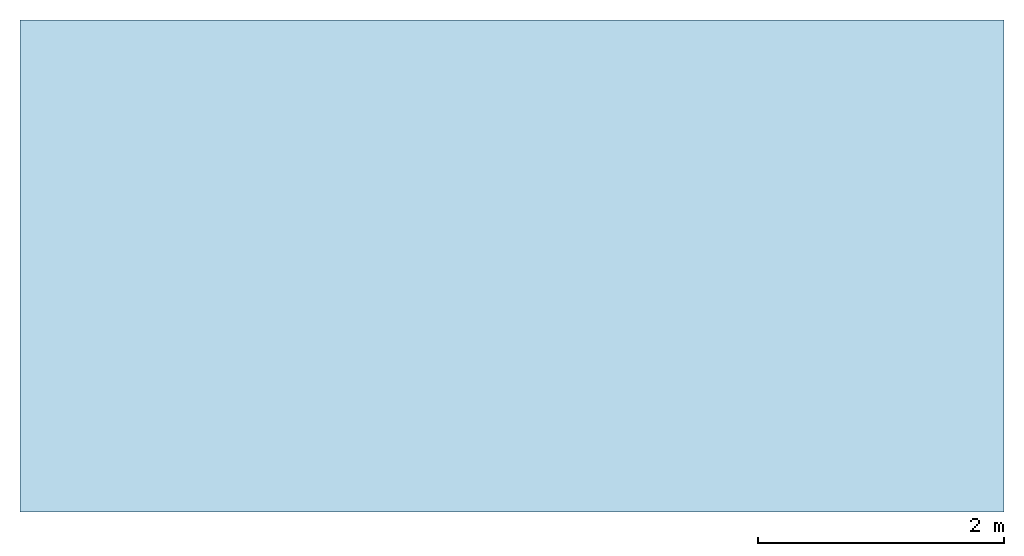
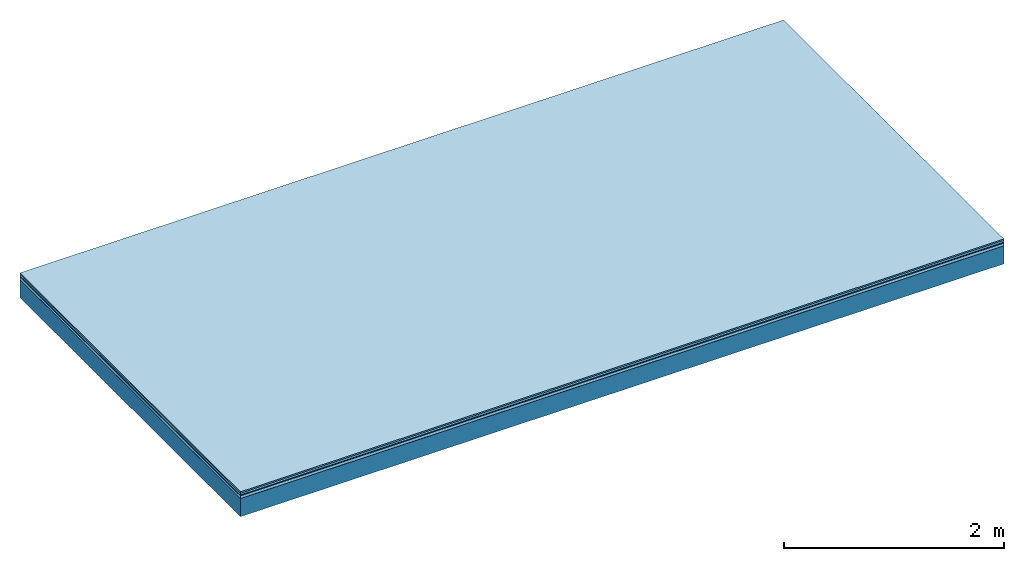
# One storey: 5 plates, 1 member, 1 element without a shape of its own.
"""IFC4 building model written with IfcOpenShell, lengths in metres."""

from ifc_helpers import new_model, si_unit, derived_unit, direction, frame, frame_2d, origin, origin_with_axes, place, context, project, spatial, rectangle, extrude, material, layer, layer_set, type_object, element, aggregate, save


model = new_model("IFC4")

# Units and contexts
plan_context = context("Plan", 3, precision=1e-05, world=origin(), true_north=direction((0.0, 1.0)))
model_context = context("Model", 3, precision=1e-05, world=origin(), true_north=direction((0.0, 1.0)))
ifc_project = project(units=[si_unit("LENGTHUNIT", "METRE"), derived_unit("SOUNDPRESSUREUNIT", [(si_unit("PRESSUREUNIT", "PASCAL", prefix="MICRO"), 0)]), si_unit("ENERGYUNIT", "JOULE", prefix="MEGA"), si_unit("MASSUNIT", "GRAM", prefix="KILO"), derived_unit("THERMALTRANSMITTANCEUNIT", [(si_unit("POWERUNIT", "WATT"), 1), (si_unit("AREAUNIT", "SQUARE_METRE"), -1), (si_unit("THERMODYNAMICTEMPERATUREUNIT", "KELVIN"), -1)]), derived_unit("AREADENSITYUNIT", [(si_unit("MASSUNIT", "GRAM", prefix="KILO"), 1), (si_unit("AREAUNIT", "SQUARE_METRE"), -1)]), derived_unit("USERDEFINED", [(si_unit("ENERGYUNIT", "JOULE", prefix="MEGA"), 1), (si_unit("AREAUNIT", "SQUARE_METRE"), -1)])], contexts=[plan_context, model_context])

# Site, building, storey
site = spatial("IfcSite", under=ifc_project)
building_placement = place(None, origin())
building = spatial("IfcBuilding", under=site, at=building_placement)
storey_placement = place(building_placement, origin())
storey = spatial("IfcBuildingStorey", under=building, at=storey_placement)

# Slab, member, plates
ifc_material_1 = material(Category="11.013")
ifc_layer_1 = layer(ifc_material_1, 0.015, Name="Flooring")
ifc_material_2 = material(Category="03.007")
ifc_layer_2 = layer(ifc_material_2, 0.02, Name="On-material")
ifc_material_3 = material(Name="Wood fiber generic product", Category="10.009")
ifc_layer_3 = layer(ifc_material_3, 0.01, Name="Impact sound insulation")
ifc_material_4 = material(Name="with broken")
ifc_layer_4 = layer(ifc_material_4, 0.03, Name="on Supporting structure")
ifc_material_5 = material(Name="protection", Category="09.007")
ifc_layer_5 = layer(ifc_material_5, 0.0005, Name="Sub-floor")
ifc_material_6 = material(Name="no composite action")
ifc_layer_6 = layer(ifc_material_6, 0.0, Name="Bond")
ifc_layer_7 = layer(None, 0.2, Name="Supporting structure")
ifc_layer_set = layer_set([ifc_layer_1, ifc_layer_2, ifc_layer_3, ifc_layer_4, ifc_layer_5, ifc_layer_6, ifc_layer_7])
slab_type = type_object("IfcSlabType", Name="A2046", PredefinedType="NOTDEFINED", material=ifc_layer_set)
slab_placement = place(None, frame((0.0, 0.0, 0.0), z_axis=(0.0, 0.0, -1.0), x_axis=(1.0, 0.0, 0.0)))
slab = element("IfcSlab", 1, at=slab_placement, inside=storey, type_object=slab_type, material=ifc_layer_set, Name="Slab #1")
ifc_material_7 = material(Name="Solid timber panel")
member_placement = place(slab_placement, origin())
member = element("IfcMember", 2, at=member_placement, material=ifc_material_7, Name="Supporting structure", context=plan_context, shape_type="SweptSolid", body=[
    extrude(rectangle(XDim=1.0, YDim=0.2, at=frame_2d((0.5, 0.1), x_axis=(1.0, 0.0))), frame((0.0, 4.0, 0.0755), z_axis=(0.0, -1.0, 0.0), x_axis=(1.0, 0.0, 0.0)), (0.0, 0.0, 1.0), 4.0),
    extrude(rectangle(XDim=1.0, YDim=0.2, at=frame_2d((0.5, 0.1), x_axis=(1.0, 0.0))), frame((1.0, 4.0, 0.0755), z_axis=(0.0, -1.0, 0.0), x_axis=(1.0, 0.0, 0.0)), (0.0, 0.0, 1.0), 4.0),
    extrude(rectangle(XDim=1.0, YDim=0.2, at=frame_2d((0.5, 0.1), x_axis=(1.0, 0.0))), frame((2.0, 4.0, 0.0755), z_axis=(0.0, -1.0, 0.0), x_axis=(1.0, 0.0, 0.0)), (0.0, 0.0, 1.0), 4.0),
    extrude(rectangle(XDim=1.0, YDim=0.2, at=frame_2d((0.5, 0.1), x_axis=(1.0, 0.0))), frame((3.0, 4.0, 0.0755), z_axis=(0.0, -1.0, 0.0), x_axis=(1.0, 0.0, 0.0)), (0.0, 0.0, 1.0), 4.0),
    extrude(rectangle(XDim=1.0, YDim=0.2, at=frame_2d((0.5, 0.1), x_axis=(1.0, 0.0))), frame((4.0, 4.0, 0.0755), z_axis=(0.0, -1.0, 0.0), x_axis=(1.0, 0.0, 0.0)), (0.0, 0.0, 1.0), 4.0),
    extrude(rectangle(XDim=1.0, YDim=0.2, at=frame_2d((0.5, 0.1), x_axis=(1.0, 0.0))), frame((5.0, 4.0, 0.0755), z_axis=(0.0, -1.0, 0.0), x_axis=(1.0, 0.0, 0.0)), (0.0, 0.0, 1.0), 4.0),
    extrude(rectangle(XDim=1.0, YDim=0.2, at=frame_2d((0.5, 0.1), x_axis=(1.0, 0.0))), frame((6.0, 4.0, 0.0755), z_axis=(0.0, -1.0, 0.0), x_axis=(1.0, 0.0, 0.0)), (0.0, 0.0, 1.0), 4.0),
    extrude(rectangle(XDim=1.0, YDim=0.2, at=frame_2d((0.5, 0.1), x_axis=(1.0, 0.0))), frame((7.0, 4.0, 0.0755), z_axis=(0.0, -1.0, 0.0), x_axis=(1.0, 0.0, 0.0)), (0.0, 0.0, 1.0), 4.0),
])
plate_1_placement = place(slab_placement, origin())
plate_1 = element("IfcPlate", 3, at=plate_1_placement, material=ifc_material_1, Name="Flooring", context=plan_context, shape_type="SweptSolid", body=[
    extrude(rectangle(XDim=8.0, YDim=4.0, at=frame_2d((4.0, 2.0), x_axis=(1.0, 0.0))), origin_with_axes(), (0.0, 0.0, 1.0), 0.015),
])
plate_2_placement = place(slab_placement, origin())
plate_2 = element("IfcPlate", 4, at=plate_2_placement, material=ifc_material_2, Name="On-material", context=plan_context, shape_type="SweptSolid", body=[
    extrude(rectangle(XDim=8.0, YDim=4.0, at=frame_2d((4.0, 2.0), x_axis=(1.0, 0.0))), frame((0.0, 0.0, 0.015), z_axis=(0.0, 0.0, 1.0), x_axis=(1.0, 0.0, 0.0)), (0.0, 0.0, 1.0), 0.02),
])
plate_3_placement = place(slab_placement, origin())
plate_3 = element("IfcPlate", 5, at=plate_3_placement, material=ifc_material_3, Name="Impact sound insulation", context=plan_context, shape_type="SweptSolid", body=[
    extrude(rectangle(XDim=8.0, YDim=4.0, at=frame_2d((4.0, 2.0), x_axis=(1.0, 0.0))), frame((0.0, 0.0, 0.035), z_axis=(0.0, 0.0, 1.0), x_axis=(1.0, 0.0, 0.0)), (0.0, 0.0, 1.0), 0.01),
])
plate_4_placement = place(slab_placement, origin())
plate_4 = element("IfcPlate", 6, at=plate_4_placement, material=ifc_material_4, Name="on Supporting structure", context=plan_context, shape_type="SweptSolid", body=[
    extrude(rectangle(XDim=8.0, YDim=4.0, at=frame_2d((4.0, 2.0), x_axis=(1.0, 0.0))), frame((0.0, 0.0, 0.045), z_axis=(0.0, 0.0, 1.0), x_axis=(1.0, 0.0, 0.0)), (0.0, 0.0, 1.0), 0.03),
])
plate_5_placement = place(slab_placement, origin())
plate_5 = element("IfcPlate", 7, at=plate_5_placement, material=ifc_material_5, Name="Sub-floor", context=plan_context, shape_type="SweptSolid", body=[
    extrude(rectangle(XDim=8.0, YDim=4.0, at=frame_2d((4.0, 2.0), x_axis=(1.0, 0.0))), frame((0.0, 0.0, 0.075), z_axis=(0.0, 0.0, 1.0), x_axis=(1.0, 0.0, 0.0)), (0.0, 0.0, 1.0), 0.0005),
])
aggregate(slab, [plate_1, plate_2, plate_3, plate_4, plate_5, member])

save(model, "model.ifc")
